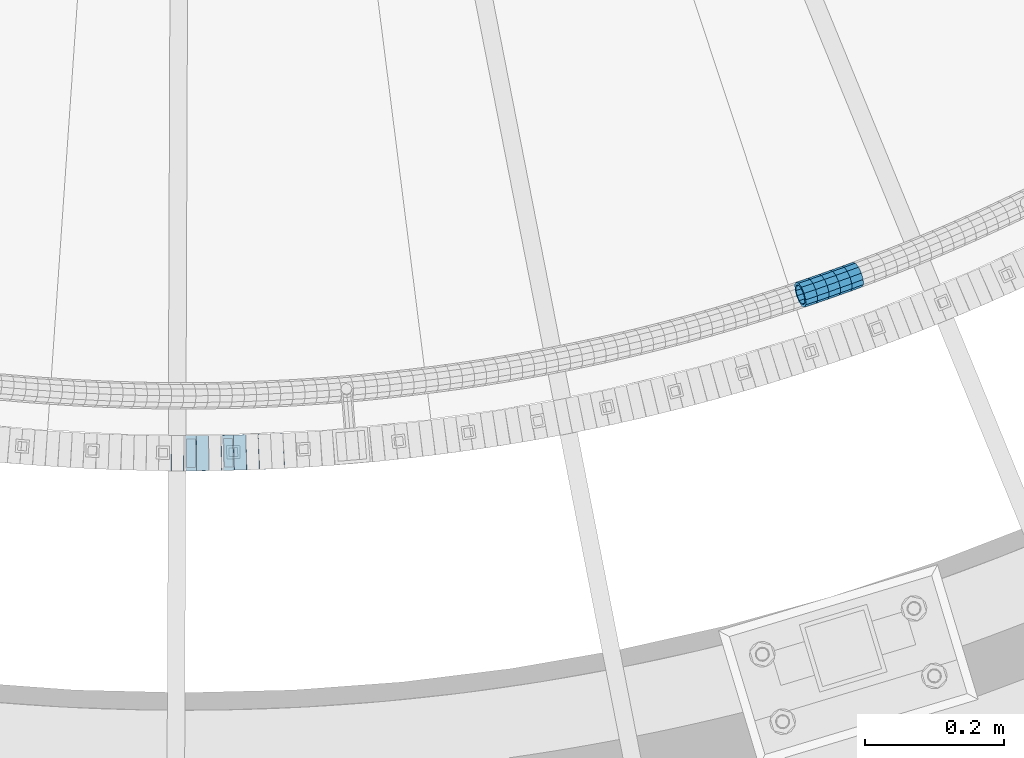
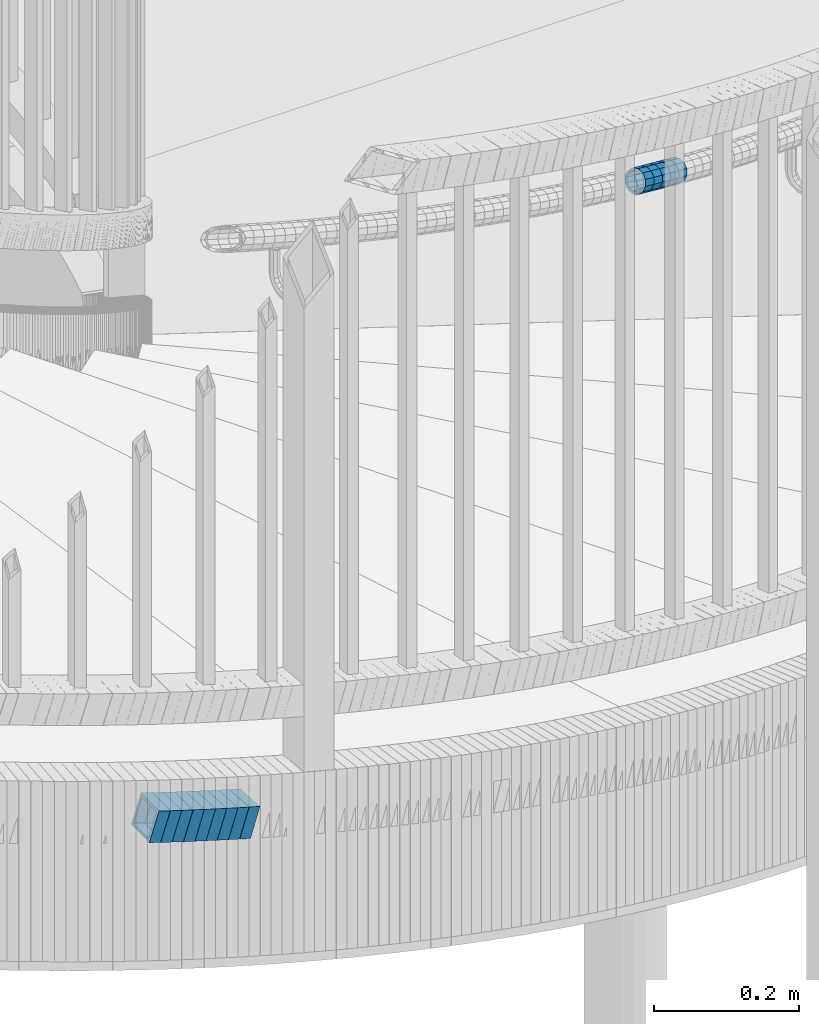
# One storey, part 680 of 975: 14 beams.
"""IFC2X3 building model written with IfcOpenShell, lengths in millimetres."""

from ifc_helpers import new_model, si_unit, frame, origin_with_axes, place, context, subcontext, project, spatial, faceted_brep, material, type_object, element, save


model = new_model("IFC2X3")

# Units and contexts
model_context = context("Model", 3, precision=1e-05, world=origin_with_axes())
body_context = subcontext(model_context, "Body", "Model", "MODEL_VIEW")
ifc_project = project(units=[si_unit("LENGTHUNIT", "METRE", prefix="MILLI"), si_unit("AREAUNIT", "SQUARE_METRE"), si_unit("VOLUMEUNIT", "CUBIC_METRE"), si_unit("MASSUNIT", "GRAM", prefix="KILO"), si_unit("TIMEUNIT", "SECOND"), si_unit("PLANEANGLEUNIT", "RADIAN"), si_unit("SOLIDANGLEUNIT", "STERADIAN"), si_unit("THERMODYNAMICTEMPERATUREUNIT", "DEGREE_CELSIUS"), si_unit("LUMINOUSINTENSITYUNIT", "LUMEN")], contexts=[model_context])

# Site, building, storey
site_placement = place(None, origin_with_axes())
site = spatial("IfcSite", under=ifc_project, at=site_placement, CompositionType="ELEMENT")
building_placement = place(site_placement, origin_with_axes())
building = spatial("IfcBuilding", under=site, at=building_placement, Name="Undefined", CompositionType="ELEMENT")
storey_placement = place(building_placement, origin_with_axes())
storey = spatial("IfcBuildingStorey", under=building, at=storey_placement, Name="Undefined", CompositionType="ELEMENT", Elevation=0.0)

# Beams
ifc_material = material()
beam_type_1 = type_object("IfcBeamType", PredefinedType="NOTDEFINED")
beam_1_placement = place(storey_placement, frame((35623.6118731889, 761.623382521388, 3913.08471142785), z_axis=(-0.319650532418957, 0.947535507051993, 1.2375357982819e-10), x_axis=(0.901043527201249, 0.303966491067887, -0.309394464069105)))
element("IfcBeam", 1, at=beam_1_placement, inside=storey, type_object=beam_type_1, material=ifc_material, Name="WALL", context=body_context, shape_type="Brep", body=[
    faceted_brep([(-2.1246523829177e-07, -15.367000000002, 0.0), (-1.83998054126278e-07, -13.3082123799541, 7.68350000000009), (18.4154826165905, -13.3082123799504, 7.68350000000646), (18.4154826165941, -15.3669999999984, 7.27595761418343e-12), (-1.06232619145885e-07, -7.68349999999919, 13.3082123799559), (18.4154826165905, -7.68349999999373, 13.308212379965), (-3.63797880709171e-12, 3.63797880709171e-12, 15.3670000000002), (18.4154826165941, 3.63797880709171e-12, 15.3670000000093), (1.06225343188271e-07, 7.68350000000646, 13.3082123799559), (18.4154826166014, 7.68349999999919, 13.3082123799722), (1.8399441614747e-07, 13.308212379965, 7.68350000000009), (18.4154826166086, 13.3082123799468, 7.68350000002465), (2.12461600312963e-07, 15.3670000000093, 0.0), (18.4154826166196, 15.366999999982, 2.91038304567337e-11), (1.8399441614747e-07, 13.308212379965, -7.68350000000009), (18.4154826166232, 13.3082123799377, -7.68349999997008), (1.06225343188271e-07, 7.68350000000646, -13.3082123799559), (18.4154826166305, 7.68349999997918, -13.308212379925), (-3.63797880709171e-12, 3.63797880709171e-12, -15.3670000000002), (18.4154826166196, -1.63709046319127e-11, -15.3669999999729), (-1.06232619145885e-07, -7.68349999999919, -13.3082123799559), (18.4154826166123, -7.68350000001374, -13.3082123799359), (-1.83998054126278e-07, -13.3082123799541, -7.68350000000009), (18.415482616605, -13.3082123799613, -7.68349999998463), (-2.63386027654633e-07, -19.0500000000029, 0.0), (-2.28097633225843e-07, -16.4977839420972, -9.52499999999964), (18.415482616605, -16.497783942099, -9.5249999999869), (18.4154826165941, -19.0499999999975, 3.63797880709171e-12), (-1.31691194837913e-07, -9.52500000000146, -16.4977839420935), (18.4154826166196, -9.52500000001601, -16.4977839420681), (-3.63797880709171e-12, 3.63797880709171e-12, -19.0500000000002), (18.4154826166268, -2.18278728425503e-11, -19.0499999999702), (1.31687556859106e-07, 9.52500000000509, -16.4977839420935), (18.4154826166305, 9.52499999997781, -16.4977839420608), (2.28097633225843e-07, 16.4977839421044, -9.52499999999964), (18.4154826166268, 16.4977839420717, -9.52499999996508), (2.63382389675826e-07, 19.0500000000138, 0.0), (18.4154826166196, 19.0499999999847, 2.5465851649642e-11), (2.28097633225843e-07, 16.4977839421044, 9.52499999999964), (18.4154826166086, 16.4977839420844, 9.52500000001965), (1.31687556859106e-07, 9.52500000000509, 16.4977839420935), (18.4154826165941, 9.52500000000146, 16.4977839421081), (-3.63797880709171e-12, 3.63797880709171e-12, 19.0500000000002), (18.4154826165868, 7.27595761418343e-12, 19.0500000000065), (-1.31691194837913e-07, -9.52500000000146, 16.4977839420935), (18.4154826165868, -9.52499999999236, 16.4977839421008), (-2.28097633225843e-07, -16.4977839420972, 9.52499999999964), (18.4154826165868, -16.4977839420862, 9.52500000000146)], [[[0, 1, 2, 3]], [[1, 4, 5, 2]], [[4, 6, 7, 5]], [[6, 8, 9, 7]], [[8, 10, 11, 9]], [[10, 12, 13, 11]], [[12, 14, 15, 13]], [[14, 16, 17, 15]], [[16, 18, 19, 17]], [[18, 20, 21, 19]], [[20, 22, 23, 21]], [[22, 0, 3, 23]], [[24, 25, 26, 27]], [[25, 28, 29, 26]], [[28, 30, 31, 29]], [[30, 32, 33, 31]], [[32, 34, 35, 33]], [[34, 36, 37, 35]], [[36, 38, 39, 37]], [[38, 40, 41, 39]], [[40, 42, 43, 41]], [[42, 44, 45, 43]], [[44, 46, 47, 45]], [[46, 24, 27, 47]], [[29, 31, 33, 35, 37, 39, 41, 43, 45, 47, 27, 26], [5, 7, 9, 11, 13, 15, 17, 19, 21, 23, 3, 2]], [[46, 44, 42, 40, 38, 36, 34, 32, 30, 28, 25, 24], [22, 20, 18, 16, 14, 12, 10, 8, 6, 4, 1, 0]]]),
])
beam_2_placement = place(storey_placement, frame((35640.2510967965, 767.169801123076, 3907.37831458484), z_axis=(-0.329843743759076, 0.944035542076143, -8.18672560853883e-11), x_axis=(0.898032292051054, 0.313770319017848, -0.308360486017532)))
element("IfcBeam", 2, at=beam_2_placement, inside=storey, type_object=beam_type_1, material=ifc_material, Name="WALL", context=body_context, shape_type="Brep", body=[
    faceted_brep([(-2.1246523829177e-07, -15.367000000002, 0.0), (-1.83998054126278e-07, -13.3082123799541, 7.68350000000009), (18.4753890351749, -13.3082123799613, 7.6835000000101), (18.4753890351676, -15.3670000000056, 0.0), (-1.06232619145885e-07, -7.68349999999919, 13.3082123799559), (18.4753890351822, -7.6835000000101, 13.3082123799686), (-3.63797880709171e-12, 3.63797880709171e-12, 15.3670000000002), (18.4753890351967, -1.2732925824821e-11, 15.3670000000238), (1.06225343188271e-07, 7.68350000000646, 13.3082123799559), (18.475389035204, 7.68349999998463, 13.3082123799832), (1.8399441614747e-07, 13.308212379965, 7.68350000000009), (18.4753890352004, 13.3082123799395, 7.68350000002465), (2.12461600312963e-07, 15.3670000000093, 0.0), (18.4753890351967, 15.3669999999838, 2.5465851649642e-11), (1.8399441614747e-07, 13.308212379965, -7.68350000000009), (18.4753890351894, 13.3082123799413, -7.68349999998463), (1.06225343188271e-07, 7.68350000000646, -13.3082123799559), (18.4753890351749, 7.68349999998827, -13.3082123799468), (-3.63797880709171e-12, 3.63797880709171e-12, -15.3670000000002), (18.4753890351676, -1.09139364212751e-11, -15.3669999999947), (-1.06232619145885e-07, -7.68349999999919, -13.3082123799559), (18.4753890351676, -7.68350000000646, -13.3082123799577), (-1.83998054126278e-07, -13.3082123799541, -7.68350000000009), (18.4753890351567, -13.3082123799613, -7.68350000000282), (-2.63386027654633e-07, -19.0500000000029, 0.0), (-2.28097633225843e-07, -16.4977839420972, -9.52499999999964), (18.4753890351567, -16.4977839420972, -9.52500000000873), (18.4753890351676, -19.0500000000065, 0.0), (-1.31691194837913e-07, -9.52500000000146, -16.4977839420935), (18.475389035164, -9.52500000000873, -16.4977839420972), (-3.63797880709171e-12, 3.63797880709171e-12, -19.0500000000002), (18.475389035164, -9.09494701772928e-12, -19.0499999999993), (1.31687556859106e-07, 9.52500000000509, -16.4977839420935), (18.4753890351822, 9.5249999999869, -16.497783942079), (2.28097633225843e-07, 16.4977839421044, -9.52499999999964), (18.4753890351931, 16.497783942079, -9.52499999997963), (2.63382389675826e-07, 19.0500000000138, 0.0), (18.475389035204, 19.0499999999847, 2.91038304567337e-11), (2.28097633225843e-07, 16.4977839421044, 9.52499999999964), (18.4753890352113, 16.4977839420753, 9.5250000000342), (1.31687556859106e-07, 9.52500000000509, 16.4977839420935), (18.475389035204, 9.52499999998327, 16.4977839421226), (-3.63797880709171e-12, 3.63797880709171e-12, 19.0500000000002), (18.4753890352004, -1.45519152283669e-11, 19.0500000000284), (-1.31691194837913e-07, -9.52500000000146, 16.4977839420935), (18.4753890351858, -9.52500000000873, 16.4977839421081), (-2.28097633225843e-07, -16.4977839420972, 9.52499999999964), (18.4753890351749, -16.4977839421008, 9.52500000000509)], [[[0, 1, 2, 3]], [[1, 4, 5, 2]], [[4, 6, 7, 5]], [[6, 8, 9, 7]], [[8, 10, 11, 9]], [[10, 12, 13, 11]], [[12, 14, 15, 13]], [[14, 16, 17, 15]], [[16, 18, 19, 17]], [[18, 20, 21, 19]], [[20, 22, 23, 21]], [[22, 0, 3, 23]], [[24, 25, 26, 27]], [[25, 28, 29, 26]], [[28, 30, 31, 29]], [[30, 32, 33, 31]], [[32, 34, 35, 33]], [[34, 36, 37, 35]], [[36, 38, 39, 37]], [[38, 40, 41, 39]], [[40, 42, 43, 41]], [[42, 44, 45, 43]], [[44, 46, 47, 45]], [[46, 24, 27, 47]], [[29, 31, 33, 35, 37, 39, 41, 43, 45, 47, 27, 26], [5, 7, 9, 11, 13, 15, 17, 19, 21, 23, 3, 2]], [[46, 44, 42, 40, 38, 36, 34, 32, 30, 28, 25, 24], [22, 20, 18, 16, 14, 12, 10, 8, 6, 4, 1, 0]]]),
])
beam_3_placement = place(storey_placement, frame((35656.7601175442, 772.891916982093, 3901.71491581384), z_axis=(-0.336697885539179, 0.941612730305536, 1.33992671180749e-10), x_axis=(0.893918401624331, 0.319643549865681, -0.314225861867966)))
element("IfcBeam", 3, at=beam_3_placement, inside=storey, type_object=beam_type_1, material=ifc_material, Name="WALL", context=body_context, shape_type="Brep", body=[
    faceted_brep([(-2.1246523829177e-07, -15.367000000002, 0.0), (-1.83998054126278e-07, -13.3082123799541, 7.68350000000009), (18.4599566630168, -13.3082123799522, 7.68349999999555), (18.4599566630277, -15.3670000000002, 3.63797880709171e-12), (-1.06232619145885e-07, -7.68349999999919, 13.3082123799559), (18.4599566630131, -7.68349999999373, 13.3082123799468), (-3.63797880709171e-12, 3.63797880709171e-12, 15.3670000000002), (18.4599566630059, 7.27595761418343e-12, 15.3669999999911), (1.06225343188271e-07, 7.68350000000646, 13.3082123799559), (18.4599566630059, 7.68350000000646, 13.3082123799431), (1.8399441614747e-07, 13.308212379965, 7.68350000000009), (18.4599566630131, 13.3082123799595, 7.68349999999555), (2.12461600312963e-07, 15.3670000000093, 0.0), (18.4599566630241, 15.3670000000002, 0.0), (1.8399441614747e-07, 13.308212379965, -7.68350000000009), (18.4599566630313, 13.3082123799522, -7.68349999999191), (1.06225343188271e-07, 7.68350000000646, -13.3082123799559), (18.459956663035, 7.68349999999555, -13.3082123799431), (-3.63797880709171e-12, 3.63797880709171e-12, -15.3670000000002), (18.459956663035, -3.63797880709171e-12, -15.3669999999875), (-1.06232619145885e-07, -7.68349999999919, -13.3082123799559), (18.459956663035, -7.68350000000464, -13.3082123799431), (-1.83998054126278e-07, -13.3082123799541, -7.68350000000009), (18.459956663035, -13.3082123799559, -7.68349999999191), (-2.63386027654633e-07, -19.0500000000029, 0.0), (-2.28097633225843e-07, -16.4977839420972, -9.52499999999964), (18.459956663035, -16.4977839420953, -9.5249999999869), (18.4599566630241, -19.0499999999975, 3.63797880709171e-12), (-1.31691194837913e-07, -9.52500000000146, -16.4977839420935), (18.4599566630386, -9.52500000000327, -16.497783942079), (-3.63797880709171e-12, 3.63797880709171e-12, -19.0500000000002), (18.4599566630422, -5.45696821063757e-12, -19.0499999999811), (1.31687556859106e-07, 9.52500000000509, -16.4977839420935), (18.4599566630386, 9.52499999999418, -16.497783942079), (2.28097633225843e-07, 16.4977839421044, -9.52499999999964), (18.4599566630277, 16.4977839420917, -9.52499999999418), (2.63382389675826e-07, 19.0500000000138, 0.0), (18.4599566630168, 19.0500000000011, -3.63797880709171e-12), (2.28097633225843e-07, 16.4977839421044, 9.52499999999964), (18.4599566630131, 16.4977839420972, 9.52499999999054), (1.31687556859106e-07, 9.52500000000509, 16.4977839420935), (18.4599566630095, 9.52500000000691, 16.497783942079), (-3.63797880709171e-12, 3.63797880709171e-12, 19.0500000000002), (18.4599566630059, 7.27595761418343e-12, 19.0499999999884), (-1.31691194837913e-07, -9.52500000000146, 16.4977839420935), (18.4599566630095, -9.52499999999236, 16.4977839420826), (-2.28097633225843e-07, -16.4977839420972, 9.52499999999964), (18.4599566630168, -16.4977839420881, 9.52499999999418)], [[[0, 1, 2, 3]], [[1, 4, 5, 2]], [[4, 6, 7, 5]], [[6, 8, 9, 7]], [[8, 10, 11, 9]], [[10, 12, 13, 11]], [[12, 14, 15, 13]], [[14, 16, 17, 15]], [[16, 18, 19, 17]], [[18, 20, 21, 19]], [[20, 22, 23, 21]], [[22, 0, 3, 23]], [[24, 25, 26, 27]], [[25, 28, 29, 26]], [[28, 30, 31, 29]], [[30, 32, 33, 31]], [[32, 34, 35, 33]], [[34, 36, 37, 35]], [[36, 38, 39, 37]], [[38, 40, 41, 39]], [[40, 42, 43, 41]], [[42, 44, 45, 43]], [[44, 46, 47, 45]], [[46, 24, 27, 47]], [[29, 31, 33, 35, 37, 39, 41, 43, 45, 47, 27, 26], [5, 7, 9, 11, 13, 15, 17, 19, 21, 23, 3, 2]], [[46, 44, 42, 40, 38, 36, 34, 32, 30, 28, 25, 24], [22, 20, 18, 16, 14, 12, 10, 8, 6, 4, 1, 0]]]),
])
beam_4_placement = place(storey_placement, frame((35673.3479260693, 778.823315182012, 3895.88431609814), z_axis=(-0.336697885539179, 0.941612730305536, 1.33992671180749e-10), x_axis=(0.895430899341175, 0.320184382121994, -0.309330674117862)))
element("IfcBeam", 4, at=beam_4_placement, inside=storey, type_object=beam_type_1, material=ifc_material, Name="WALL", context=body_context, shape_type="Brep", body=[
    faceted_brep([(-2.1246523829177e-07, -15.367000000002, 0.0), (-1.83998054126278e-07, -13.3082123799541, 7.68350000000009), (18.428781837134, -13.3082123799413, 7.68349999998827), (18.4287818371195, -15.3669999999802, -2.5465851649642e-11), (-1.06232619145885e-07, -7.68349999999919, 13.3082123799559), (18.4287818371522, -7.68349999999373, 13.3082123799577), (-3.63797880709171e-12, 3.63797880709171e-12, 15.3670000000002), (18.4287818371486, 5.45696821063757e-12, 15.367000000002), (1.06225343188271e-07, 7.68350000000646, 13.3082123799559), (18.4287818371558, 7.68350000000282, 13.3082123799577), (1.8399441614747e-07, 13.308212379965, 7.68350000000009), (18.4287818371413, 13.3082123799595, 7.68349999999191), (2.12461600312963e-07, 15.3670000000093, 0.0), (18.4287818371267, 15.3670000000075, -2.18278728425503e-11), (1.8399441614747e-07, 13.308212379965, -7.68350000000009), (18.4287818371122, 13.3082123799668, -7.68350000003193), (1.06225343188271e-07, 7.68350000000646, -13.3082123799559), (18.4287818370976, 7.68350000001737, -13.3082123800014), (-3.63797880709171e-12, 3.63797880709171e-12, -15.3670000000002), (18.428781837094, 2.00088834390044e-11, -15.3670000000529), (-1.06232619145885e-07, -7.68349999999919, -13.3082123799559), (18.4287818370976, -7.68349999997554, -13.308212380005), (-1.83998054126278e-07, -13.3082123799541, -7.68350000000009), (18.4287818371085, -13.308212379934, -7.6835000000392), (-2.63386027654633e-07, -19.0500000000029, 0.0), (-2.28097633225843e-07, -16.4977839420972, -9.52499999999964), (18.4287818371049, -16.4977839420699, -9.52500000004511), (18.4287818371231, -19.0499999999793, -2.5465851649642e-11), (-1.31691194837913e-07, -9.52500000000146, -16.4977839420935), (18.4287818370904, -9.52499999997599, -16.4977839421445), (-3.63797880709171e-12, 3.63797880709171e-12, -19.0500000000002), (18.4287818370831, 2.36468622460961e-11, -19.0500000000611), (1.31687556859106e-07, 9.52500000000509, -16.4977839420935), (18.4287818370904, 9.52500000001965, -16.4977839421481), (2.28097633225843e-07, 16.4977839421044, -9.52499999999964), (18.4287818371049, 16.4977839421063, -9.52500000004147), (2.63382389675826e-07, 19.0500000000138, 0.0), (18.4287818371304, 19.0500000000047, -2.18278728425503e-11), (2.28097633225843e-07, 16.4977839421044, 9.52499999999964), (18.4287818371486, 16.4977839420953, 9.52499999999782), (1.31687556859106e-07, 9.52500000000509, 16.4977839420935), (18.4287818371558, 9.52500000000146, 16.4977839421044), (-3.63797880709171e-12, 3.63797880709171e-12, 19.0500000000002), (18.4287818371631, 1.81898940354586e-12, 19.0500000000138), (-1.31691194837913e-07, -9.52500000000146, 16.4977839420935), (18.4287818371595, -9.52499999999236, 16.4977839421044), (-2.28097633225843e-07, -16.4977839420972, 9.52499999999964), (18.4287818371449, -16.4977839420808, 9.52499999999418)], [[[0, 1, 2, 3]], [[1, 4, 5, 2]], [[4, 6, 7, 5]], [[6, 8, 9, 7]], [[8, 10, 11, 9]], [[10, 12, 13, 11]], [[12, 14, 15, 13]], [[14, 16, 17, 15]], [[16, 18, 19, 17]], [[18, 20, 21, 19]], [[20, 22, 23, 21]], [[22, 0, 3, 23]], [[24, 25, 26, 27]], [[25, 28, 29, 26]], [[28, 30, 31, 29]], [[30, 32, 33, 31]], [[32, 34, 35, 33]], [[34, 36, 37, 35]], [[36, 38, 39, 37]], [[38, 40, 41, 39]], [[40, 42, 43, 41]], [[42, 44, 45, 43]], [[44, 46, 47, 45]], [[46, 24, 27, 47]], [[29, 31, 33, 35, 37, 39, 41, 43, 45, 47, 27, 26], [5, 7, 9, 11, 13, 15, 17, 19, 21, 23, 3, 2]], [[46, 44, 42, 40, 38, 36, 34, 32, 30, 28, 25, 24], [22, 20, 18, 16, 14, 12, 10, 8, 6, 4, 1, 0]]]),
])
beam_5_placement = place(storey_placement, frame((35689.7787989532, 784.61783831661, 3890.21751064007), z_axis=(-0.348616965564528, 0.937265283321953, 1.38182258524466e-10), x_axis=(0.889663494204294, 0.330911422075981, -0.31463708907225)))
element("IfcBeam", 5, at=beam_5_placement, inside=storey, type_object=beam_type_1, material=ifc_material, Name="WALL", context=body_context, shape_type="Brep", body=[
    faceted_brep([(-2.1246523829177e-07, -15.367000000002, 0.0), (-1.83998054126278e-07, -13.3082123799541, 7.68350000000009), (18.428781837134, -13.3082123799413, 7.68349999998827), (18.4287818371195, -15.3669999999802, -2.5465851649642e-11), (-1.06232619145885e-07, -7.68349999999919, 13.3082123799559), (18.4287818371522, -7.68349999999373, 13.3082123799577), (-3.63797880709171e-12, 3.63797880709171e-12, 15.3670000000002), (18.4287818371486, 5.45696821063757e-12, 15.367000000002), (1.06225343188271e-07, 7.68350000000646, 13.3082123799559), (18.4287818371558, 7.68350000000282, 13.3082123799577), (1.8399441614747e-07, 13.308212379965, 7.68350000000009), (18.4287818371413, 13.3082123799595, 7.68349999999191), (2.12461600312963e-07, 15.3670000000093, 0.0), (18.4287818371267, 15.3670000000075, -2.18278728425503e-11), (1.8399441614747e-07, 13.308212379965, -7.68350000000009), (18.4287818371122, 13.3082123799668, -7.68350000003193), (1.06225343188271e-07, 7.68350000000646, -13.3082123799559), (18.4287818370976, 7.68350000001737, -13.3082123800014), (-3.63797880709171e-12, 3.63797880709171e-12, -15.3670000000002), (18.428781837094, 2.00088834390044e-11, -15.3670000000529), (-1.06232619145885e-07, -7.68349999999919, -13.3082123799559), (18.4287818370976, -7.68349999997554, -13.308212380005), (-1.83998054126278e-07, -13.3082123799541, -7.68350000000009), (18.4287818371085, -13.308212379934, -7.6835000000392), (-2.63386027654633e-07, -19.0500000000029, 0.0), (-2.28097633225843e-07, -16.4977839420972, -9.52499999999964), (18.4287818371049, -16.4977839420699, -9.52500000004511), (18.4287818371231, -19.0499999999793, -2.5465851649642e-11), (-1.31691194837913e-07, -9.52500000000146, -16.4977839420935), (18.4287818370904, -9.52499999997599, -16.4977839421445), (-3.63797880709171e-12, 3.63797880709171e-12, -19.0500000000002), (18.4287818370831, 2.36468622460961e-11, -19.0500000000611), (1.31687556859106e-07, 9.52500000000509, -16.4977839420935), (18.4287818370904, 9.52500000001965, -16.4977839421481), (2.28097633225843e-07, 16.4977839421044, -9.52499999999964), (18.4287818371049, 16.4977839421063, -9.52500000004147), (2.63382389675826e-07, 19.0500000000138, 0.0), (18.4287818371304, 19.0500000000047, -2.18278728425503e-11), (2.28097633225843e-07, 16.4977839421044, 9.52499999999964), (18.4287818371486, 16.4977839420953, 9.52499999999782), (1.31687556859106e-07, 9.52500000000509, 16.4977839420935), (18.4287818371558, 9.52500000000146, 16.4977839421044), (-3.63797880709171e-12, 3.63797880709171e-12, 19.0500000000002), (18.4287818371631, 1.81898940354586e-12, 19.0500000000138), (-1.31691194837913e-07, -9.52500000000146, 16.4977839420935), (18.4287818371595, -9.52499999999236, 16.4977839421044), (-2.28097633225843e-07, -16.4977839420972, 9.52499999999964), (18.4287818371449, -16.4977839420808, 9.52499999999418)], [[[0, 1, 2, 3]], [[1, 4, 5, 2]], [[4, 6, 7, 5]], [[6, 8, 9, 7]], [[8, 10, 11, 9]], [[10, 12, 13, 11]], [[12, 14, 15, 13]], [[14, 16, 17, 15]], [[16, 18, 19, 17]], [[18, 20, 21, 19]], [[20, 22, 23, 21]], [[22, 0, 3, 23]], [[24, 25, 26, 27]], [[25, 28, 29, 26]], [[28, 30, 31, 29]], [[30, 32, 33, 31]], [[32, 34, 35, 33]], [[34, 36, 37, 35]], [[36, 38, 39, 37]], [[38, 40, 41, 39]], [[40, 42, 43, 41]], [[42, 44, 45, 43]], [[44, 46, 47, 45]], [[46, 24, 27, 47]], [[29, 31, 33, 35, 37, 39, 41, 43, 45, 47, 27, 26], [5, 7, 9, 11, 13, 15, 17, 19, 21, 23, 3, 2]], [[46, 44, 42, 40, 38, 36, 34, 32, 30, 28, 25, 24], [22, 20, 18, 16, 14, 12, 10, 8, 6, 4, 1, 0]]]),
])
beam_type_2 = type_object("IfcBeamType", Name="HSS2X2X.188_TUBES", PredefinedType="NOTDEFINED")
beam_6_placement = place(storey_placement, frame((34708.4765346238, 533.017847387491, 3296.60996959345), z_axis=(0.00561788911536132, 0.999984219536432, -3.77735887013841e-11), x_axis=(0.952348373448956, -0.00535027200252182, -0.304965490143765)))
element("IfcBeam", 6, at=beam_6_placement, inside=storey, type_object=beam_type_2, material=ifc_material, Name="WALL", ObjectType="HSS2X2X.188_TUBES", context=body_context, shape_type="Brep", body=[
    faceted_brep([(0.0, 20.6374999999753, -20.6375000000298), (0.0, -20.6375000000153, -20.6375000000153), (18.6895692834223, -20.637499999988, -20.6374999999862), (18.6895692834369, 20.6374999999953, -20.6374999999534), (0.0, -20.6374999999825, 20.6375000000335), (18.6895692833914, -20.637499999988, 20.6374999999789), (0.0, 20.6375000000116, 20.6375000000189), (18.6895692834078, 20.6374999999953, 20.637500000008), (0.0, 25.3999999999724, -25.4000000000342), (0.0, 25.400000000016, 25.4000000000196), (18.6895692834059, 25.3999999999924, 25.4000000000087), (18.6895692834423, 25.3999999999942, -25.3999999999432), (0.0, -25.399999999976, 25.4000000000378), (18.6895692833878, -25.3999999999869, 25.3999999999687), (0.0, -25.400000000016, -25.4000000000196), (18.6895692834241, -25.3999999999869, -25.3999999999833)], [[[0, 1, 2, 3]], [[1, 4, 5, 2]], [[4, 6, 7, 5]], [[6, 0, 3, 7]], [[8, 9, 10, 11]], [[9, 12, 13, 10]], [[12, 14, 15, 13]], [[14, 8, 11, 15]], [[13, 15, 11, 10], [5, 7, 3, 2]], [[14, 12, 9, 8], [6, 4, 1, 0]]]),
])
beam_7_placement = place(storey_placement, frame((34726.4779434328, 532.830587602682, 3290.93676420078), z_axis=(-0.00558650531555759, 0.999984395357427, 1.0159783414565e-10), x_axis=(0.951293651453999, 0.00531449000253813, -0.308240401147109)))
element("IfcBeam", 7, at=beam_7_placement, inside=storey, type_object=beam_type_2, material=ifc_material, Name="WALL", ObjectType="HSS2X2X.188_TUBES", context=body_context, shape_type="Brep", body=[
    faceted_brep([(0.0, 20.6374999999753, -20.6375000000298), (0.0, -20.6375000000153, -20.6375000000153), (18.8225928075335, -20.6374999999935, -20.6375000000298), (18.8225928075699, 20.6374999999898, -20.6374999999825), (0.0, -20.6374999999825, 20.6375000000335), (18.8225928075772, -20.637500000008, 20.6375000000226), (0.0, 20.6375000000116, 20.6375000000189), (18.8225928076135, 20.6374999999753, 20.6375000000698), (0.0, 25.3999999999724, -25.4000000000342), (0.0, 25.400000000016, 25.4000000000196), (18.8225928076281, 25.3999999999705, 25.4000000000815), (18.8225928075663, 25.3999999999905, -25.3999999999796), (0.0, -25.399999999976, 25.4000000000378), (18.8225928075808, -25.4000000000087, 25.4000000000233), (0.0, -25.400000000016, -25.4000000000196), (18.8225928075226, -25.3999999999905, -25.4000000000378)], [[[0, 1, 2, 3]], [[1, 4, 5, 2]], [[4, 6, 7, 5]], [[6, 0, 3, 7]], [[8, 9, 10, 11]], [[9, 12, 13, 10]], [[12, 14, 15, 13]], [[14, 8, 11, 15]], [[13, 15, 11, 10], [5, 7, 3, 2]], [[14, 12, 9, 8], [6, 4, 1, 0]]]),
])
beam_8_placement = place(storey_placement, frame((34744.5004033218, 532.93127173614, 3285.09742680517), z_axis=(-0.00558650531555759, 0.999984395357427, 1.0159783414565e-10), x_axis=(0.952842343809516, 0.00532314199893685, -0.30341906993933)))
element("IfcBeam", 8, at=beam_8_placement, inside=storey, type_object=beam_type_2, material=ifc_material, Name="WALL", ObjectType="HSS2X2X.188_TUBES", context=body_context, shape_type="Brep", body=[
    faceted_brep([(0.0, 20.6374999999753, -20.6375000000298), (0.0, -20.6375000000153, -20.6375000000153), (18.7853666454903, -20.6375000000535, -20.6375000000326), (18.785366645363, 20.6374999999862, -20.6375000000044), (0.0, -20.6374999999825, 20.6375000000335), (18.785366645352, -20.6375000000007, 20.6374999999989), (0.0, 20.6375000000116, 20.6375000000189), (18.7853666453102, 20.6375000000025, 20.6374999999753), (0.0, 25.3999999999724, -25.4000000000342), (0.0, 25.400000000016, 25.4000000000196), (18.7853666452065, 25.4000000000451, 25.4000000000351), (18.7853666453739, 25.3999999999833, -25.400000000006), (0.0, -25.399999999976, 25.4000000000378), (18.7853666497213, -25.399999993424, 25.3999999995158), (0.0, -25.400000000016, -25.4000000000196), (18.7853666455194, -25.4000000000633, -25.4000000000406)], [[[0, 1, 2, 3]], [[1, 4, 5, 2]], [[4, 6, 7, 5]], [[6, 0, 3, 7]], [[8, 9, 10, 11]], [[9, 12, 13, 10]], [[12, 14, 15, 13]], [[14, 8, 11, 15]], [[13, 15, 11, 10], [5, 7, 3, 2]], [[14, 12, 9, 8], [6, 4, 1, 0]]]),
])
beam_9_placement = place(storey_placement, frame((34762.6491224577, 532.947017273088, 3279.4096856433), z_axis=(-0.0168515395668437, 0.999858002725501, 1.82946223503677e-10), x_axis=(0.952239346781279, 0.0160489779963114, -0.30493057692996)))
element("IfcBeam", 9, at=beam_9_placement, inside=storey, type_object=beam_type_2, material=ifc_material, Name="WALL", ObjectType="HSS2X2X.188_TUBES", context=body_context, shape_type="Brep", body=[
    faceted_brep([(0.0, 20.6374999999753, -20.6375000000298), (0.0, -20.6375000000153, -20.6375000000153), (18.6895692834223, -20.637499999988, -20.6374999999862), (18.6895692834369, 20.6374999999953, -20.6374999999534), (0.0, -20.6374999999825, 20.6375000000335), (18.6895692833914, -20.637499999988, 20.6374999999789), (0.0, 20.6375000000116, 20.6375000000189), (18.6895692834078, 20.6374999999953, 20.637500000008), (0.0, 25.3999999999724, -25.4000000000342), (0.0, 25.400000000016, 25.4000000000196), (18.6895692834059, 25.3999999999924, 25.4000000000087), (18.6895692834423, 25.3999999999942, -25.3999999999432), (0.0, -25.399999999976, 25.4000000000378), (18.6895692833878, -25.3999999999869, 25.3999999999687), (0.0, -25.400000000016, -25.4000000000196), (18.6895692834241, -25.3999999999869, -25.3999999999833)], [[[0, 1, 2, 3]], [[1, 4, 5, 2]], [[4, 6, 7, 5]], [[6, 0, 3, 7]], [[8, 9, 10, 11]], [[9, 12, 13, 10]], [[12, 14, 15, 13]], [[14, 8, 11, 15]], [[13, 15, 11, 10], [5, 7, 3, 2]], [[14, 12, 9, 8], [6, 4, 1, 0]]]),
])
beam_10_placement = place(storey_placement, frame((34780.6294023766, 533.208128779979, 3273.69690549078), z_axis=(-0.0223407916099386, 0.999750413368377, 1.91507751878817e-10), x_axis=(0.952639911187478, 0.0212880430041895, -0.303354609059705)))
element("IfcBeam", 10, at=beam_10_placement, inside=storey, type_object=beam_type_2, material=ifc_material, Name="WALL", ObjectType="HSS2X2X.188_TUBES", context=body_context, shape_type="Brep", body=[
    faceted_brep([(0.0, 20.6374999999753, -20.6375000000298), (0.0, -20.6375000000153, -20.6375000000153), (18.7853666454903, -20.6375000000535, -20.6375000000326), (18.785366645363, 20.6374999999862, -20.6375000000044), (0.0, -20.6374999999825, 20.6375000000335), (18.785366645352, -20.6375000000007, 20.6374999999989), (0.0, 20.6375000000116, 20.6375000000189), (18.7853666453102, 20.6375000000025, 20.6374999999753), (0.0, 25.3999999999724, -25.4000000000342), (0.0, 25.400000000016, 25.4000000000196), (18.7853666452065, 25.4000000000451, 25.4000000000351), (18.7853666453739, 25.3999999999833, -25.400000000006), (0.0, -25.399999999976, 25.4000000000378), (18.7853666497213, -25.399999993424, 25.3999999995158), (0.0, -25.400000000016, -25.4000000000196), (18.7853666455194, -25.4000000000633, -25.4000000000406)], [[[0, 1, 2, 3]], [[1, 4, 5, 2]], [[4, 6, 7, 5]], [[6, 0, 3, 7]], [[8, 9, 10, 11]], [[9, 12, 13, 10]], [[12, 14, 15, 13]], [[14, 8, 11, 15]], [[13, 15, 11, 10], [5, 7, 3, 2]], [[14, 12, 9, 8], [6, 4, 1, 0]]]),
])
beam_11_placement = place(storey_placement, frame((34798.5151476775, 533.563065833007, 3268.04881015067), z_axis=(-0.0280788119629869, 0.999605712428029, -1.59657247422729e-11), x_axis=(0.950459344102329, 0.0266982960028744, -0.309700236033352)))
element("IfcBeam", 11, at=beam_11_placement, inside=storey, type_object=beam_type_2, material=ifc_material, Name="WALL", ObjectType="HSS2X2X.188_TUBES", context=body_context, shape_type="Brep", body=[
    faceted_brep([(0.0, 20.6374999999753, -20.6375000000298), (0.0, -20.6375000000153, -20.6375000000153), (18.7347271129966, -20.6375000000116, -20.6375000000262), (18.7347271130257, 20.6374999999989, -20.6374999999935), (0.0, -20.6374999999825, 20.6375000000335), (18.7347271129947, -20.6375000000116, 20.6374999999607), (0.0, 20.6375000000116, 20.6375000000189), (18.7347271130147, 20.6375000000007, 20.6374999999898), (0.0, 25.3999999999724, -25.4000000000342), (0.0, 25.400000000016, 25.4000000000196), (18.7347271130166, 25.4000000000015, 25.3999999999905), (18.7347271130257, 25.3999999999996, -25.3999999999869), (0.0, -25.399999999976, 25.4000000000378), (18.7347271129875, -25.4000000000106, 25.3999999999505), (0.0, -25.400000000016, -25.4000000000196), (18.7347271130002, -25.4000000000124, -25.4000000000233)], [[[0, 1, 2, 3]], [[1, 4, 5, 2]], [[4, 6, 7, 5]], [[6, 0, 3, 7]], [[8, 9, 10, 11]], [[9, 12, 13, 10]], [[12, 14, 15, 13]], [[14, 8, 11, 15]], [[13, 15, 11, 10], [5, 7, 3, 2]], [[14, 12, 9, 8], [6, 4, 1, 0]]]),
])
beam_12_placement = place(storey_placement, frame((34816.617447157, 534.030129863479, 3262.19621111105), z_axis=(-0.0335007387218502, 0.999438692719614, 2.3259462977876e-10), x_axis=(0.952370201964091, 0.0319230239987988, -0.30326872398856)))
element("IfcBeam", 12, at=beam_12_placement, inside=storey, type_object=beam_type_2, material=ifc_material, Name="WALL", ObjectType="HSS2X2X.188_TUBES", context=body_context, shape_type="Brep", body=[
    faceted_brep([(0.0, 20.6374999999753, -20.6375000000298), (0.0, -20.6375000000153, -20.6375000000153), (18.8047866246379, -20.6374999999916, -20.6375000000298), (18.8047866247143, 20.6374999999844, -20.6374999999643), (0.0, -20.6374999999825, 20.6375000000335), (18.8047866247107, -20.6375000000189, 20.6375000000407), (0.0, 20.6375000000116, 20.6375000000189), (18.8047866247907, 20.6374999999589, 20.6375000001026), (0.0, 25.3999999999724, -25.4000000000342), (0.0, 25.400000000016, 25.4000000000196), (18.8047866248016, 25.3999999999542, 25.4000000001142), (18.8047866247143, 25.3999999999851, -25.3999999999651), (0.0, -25.399999999976, 25.4000000000378), (18.8047866247107, -25.4000000000196, 25.4000000000415), (0.0, -25.400000000016, -25.4000000000196), (18.8047866246197, -25.3999999999887, -25.4000000000378)], [[[0, 1, 2, 3]], [[1, 4, 5, 2]], [[4, 6, 7, 5]], [[6, 0, 3, 7]], [[8, 9, 10, 11]], [[9, 12, 13, 10]], [[12, 14, 15, 13]], [[14, 8, 11, 15]], [[13, 15, 11, 10], [5, 7, 3, 2]], [[14, 12, 9, 8], [6, 4, 1, 0]]]),
])
beam_13_placement = place(storey_placement, frame((34834.628506586, 534.589369128803, 3256.50826789052), z_axis=(-0.0392954688246173, 0.999227634790919, -5.34450919076335e-11), x_axis=(0.951694774098575, 0.0374261990038736, -0.304756192031572)))
element("IfcBeam", 13, at=beam_13_placement, inside=storey, type_object=beam_type_2, material=ifc_material, Name="WALL", ObjectType="HSS2X2X.188_TUBES", context=body_context, shape_type="Brep", body=[
    faceted_brep([(0.0, 20.6374999999753, -20.6375000000298), (0.0, -20.6375000000153, -20.6375000000153), (18.6959888745805, -20.6374999999771, -20.6375000000407), (18.6959888746751, 20.637499999988, -20.6374999999716), (0.0, -20.6374999999825, 20.6375000000335), (18.6959888746969, -20.6375000000135, 20.6375000000371), (0.0, 20.6375000000116, 20.6375000000189), (18.6959888747988, 20.6374999999498, 20.6375000001062), (0.0, 25.3999999999724, -25.4000000000342), (0.0, 25.400000000016, 25.4000000000196), (18.695988874817, 25.3999999999414, 25.4000000001215), (18.6959888746678, 25.3999999999887, -25.399999999976), (0.0, -25.399999999976, 25.4000000000378), (18.6959888747042, -25.4000000000124, 25.4000000000378), (0.0, -25.400000000016, -25.4000000000196), (18.695988874555, -25.3999999999687, -25.4000000000597)], [[[0, 1, 2, 3]], [[1, 4, 5, 2]], [[4, 6, 7, 5]], [[6, 0, 3, 7]], [[8, 9, 10, 11]], [[9, 12, 13, 10]], [[12, 14, 15, 13]], [[14, 8, 11, 15]], [[13, 15, 11, 10], [5, 7, 3, 2]], [[14, 12, 9, 8], [6, 4, 1, 0]]]),
])
beam_14_placement = place(storey_placement, frame((34852.7204634099, 535.215623939814, 3250.80713608023), z_axis=(-0.050497290906249, 0.998724197970155, -2.94621713692322e-11), x_axis=(0.951259788389675, 0.0480974050197124, -0.304616898124843)))
element("IfcBeam", 14, at=beam_14_placement, inside=storey, type_object=beam_type_2, material=ifc_material, Name="WALL", ObjectType="HSS2X2X.188_TUBES", context=body_context, shape_type="Brep", body=[
    faceted_brep([(0.0, 20.6374999999753, -20.6375000000298), (0.0, -20.6375000000153, -20.6375000000153), (18.7112265765609, -20.6375000000062, -20.6374999999862), (18.7112265765645, 20.6374999999898, -20.6374999999789), (0.0, -20.6374999999825, 20.6375000000335), (18.7112265765209, -20.6374999999916, 20.6374999999607), (0.0, 20.6375000000116, 20.6375000000189), (18.7112265765245, 20.6375000000025, 20.6374999999716), (0.0, 25.3999999999724, -25.4000000000342), (0.0, 25.400000000016, 25.4000000000196), (18.7112265765172, 25.4000000000051, 25.3999999999614), (18.7112265765718, 25.3999999999887, -25.3999999999724), (0.0, -25.399999999976, 25.4000000000378), (18.7112265765136, -25.3999999999905, 25.3999999999542), (0.0, -25.400000000016, -25.4000000000196), (18.7112265765682, -25.4000000000069, -25.3999999999796)], [[[0, 1, 2, 3]], [[1, 4, 5, 2]], [[4, 6, 7, 5]], [[6, 0, 3, 7]], [[8, 9, 10, 11]], [[9, 12, 13, 10]], [[12, 14, 15, 13]], [[14, 8, 11, 15]], [[13, 15, 11, 10], [5, 7, 3, 2]], [[14, 12, 9, 8], [6, 4, 1, 0]]]),
])

save(model, "model.ifc")
